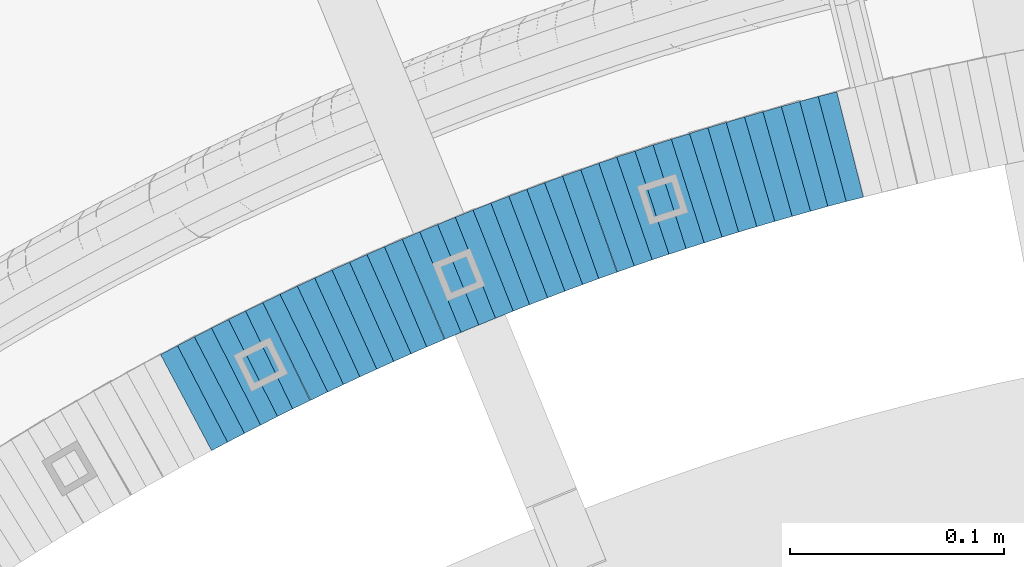
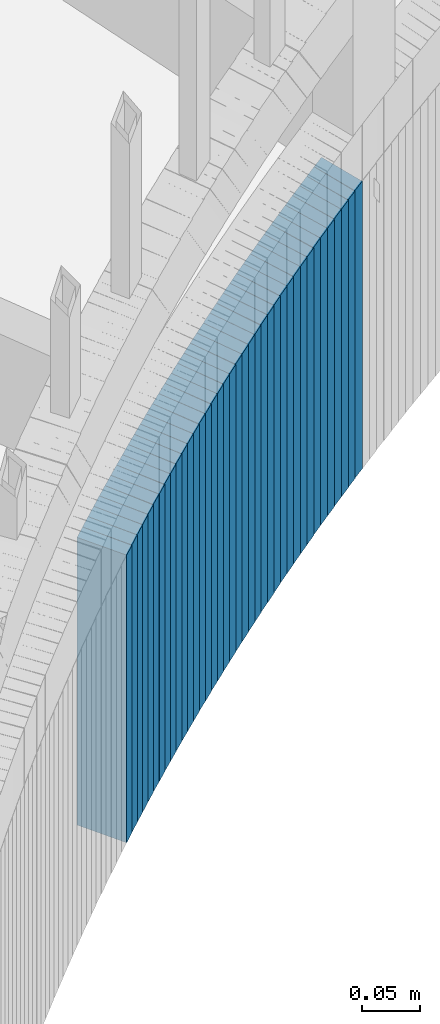
# One storey, part 896 of 975: 38 plates.
"""IFC2X3 building model written with IfcOpenShell, lengths in millimetres."""

import ifcopenshell
import ifcopenshell.guid

model = None  # the IFC model being written
_history = None  # IfcOwnerHistory: only IFC2X3 demands one
_inside = {}  # id of a spatial element -> (the spatial element, [elements in it])
_under = {}  # id of a project, library or spatial element -> (it, [spatial elements below it])
_declared = {}  # id of a project -> (the project, [libraries it declares])
_typed = {}  # id of a type object -> (the type object, [elements of that type])
_made_of = {}  # id of a material, layer set ... -> (it, [elements and type objects made of it])


def new_model(schema):
    """Start an empty IFC model of exactly this schema.

    Asked for "IFC4X3", IfcOpenShell would pick the latest addendum, in which some entities
    have other attributes; the version numbers below select the first issue.
    IFC2X3 requires an IfcOwnerHistory on every rooted entity: one is made here for all.
    """
    global model, _history
    if schema == "IFC4X3":
        model = ifcopenshell.file(schema_version=(4, 3, 0, 0))
    else:
        model = ifcopenshell.file(schema=schema)
    _inside.clear()
    _under.clear()
    _declared.clear()
    _typed.clear()
    _made_of.clear()
    _history = None
    if model.schema == "IFC2X3":
        org = make("IfcOrganization", Name="unknown")
        user = make(
            "IfcPersonAndOrganization",
            ThePerson=make("IfcPerson", FamilyName="unknown"),
            TheOrganization=org,
        )
        app = make(
            "IfcApplication",
            ApplicationDeveloper=org,
            Version="unknown",
            ApplicationFullName="unknown",
            ApplicationIdentifier="unknown",
        )
        _history = make(
            "IfcOwnerHistory",
            OwningUser=user,
            OwningApplication=app,
            ChangeAction="ADDED",
            CreationDate=0,
        )
    return model


def make(cls, **values):
    """One entity of the class cls with the attributes given. An attribute that is None is left unset."""
    return model.create_entity(
        cls, **{name: value for name, value in values.items() if value is not None}
    )


def rooted(cls, **values):
    """An entity with a GlobalId (a new one), such as an element, a storey or a relation."""
    return make(cls, GlobalId=ifcopenshell.guid.new(), OwnerHistory=_history, **values)


def si_unit(unit_type, name, prefix=None):
    """IfcSIUnit, for example si_unit("LENGTHUNIT", "METRE", prefix="MILLI")."""
    return make("IfcSIUnit", UnitType=unit_type, Prefix=prefix, Name=name)


def assignment(units):
    """IfcUnitAssignment: the units of a project."""
    return None if units is None else make("IfcUnitAssignment", Units=units)


def point(xyz):
    """IfcCartesianPoint."""
    return None if xyz is None else make("IfcCartesianPoint", Coordinates=xyz)


def direction(xyz):
    """IfcDirection."""
    return None if xyz is None else make("IfcDirection", DirectionRatios=xyz)


def frame(location, z_axis=None, x_axis=None):
    """IfcAxis2Placement3D, a coordinate frame: its origin and axes. An axis left out is left unset."""
    return make(
        "IfcAxis2Placement3D",
        Location=point(location),
        Axis=direction(z_axis),
        RefDirection=direction(x_axis),
    )


def origin_with_axes():
    """The frame at (0, 0, 0) with the z axis (0, 0, 1) and the x axis (1, 0, 0) written out."""
    return frame((0.0, 0.0, 0.0), z_axis=(0.0, 0.0, 1.0), x_axis=(1.0, 0.0, 0.0))


def place(relative_to, where):
    """IfcLocalPlacement: puts the frame where relative to a parent placement (None: the world)."""
    return make(
        "IfcLocalPlacement", PlacementRelTo=relative_to, RelativePlacement=where
    )


def context(
    kind, dimensions, precision=None, world=None, true_north=None, identifier=None
):
    """IfcGeometricRepresentationContext, for example the 3D "Model" context."""
    return make(
        "IfcGeometricRepresentationContext",
        ContextIdentifier=identifier,
        ContextType=kind,
        CoordinateSpaceDimension=dimensions,
        Precision=precision,
        WorldCoordinateSystem=world,
        TrueNorth=true_north,
    )


def subcontext(parent, identifier, kind, view, scale=None):
    """IfcGeometricRepresentationSubContext, for example "Body" below "Model"."""
    return make(
        "IfcGeometricRepresentationSubContext",
        ContextIdentifier=identifier,
        ContextType=kind,
        ParentContext=parent,
        TargetScale=scale,
        TargetView=view,
    )


def project(units=None, contexts=None):
    """IfcProject with its units and contexts."""
    return rooted(
        "IfcProject",
        Name="project",
        RepresentationContexts=contexts,
        UnitsInContext=assignment(units),
    )


def spatial(cls, under=None, at=None, **own):
    """A site, building, storey or space (cls), placed at a placement, below another one or the project."""
    s = rooted(cls, ObjectPlacement=at, **own)
    if under is not None:
        _under.setdefault(under.id(), (under, []))[1].append(s)
    return s


def faces_of(points, faces, orient=None, outer=None):
    """IfcFace entities. A face is a list of loops; a loop is a list of indices into points, from 0.

    orient and outer hold one flag for each loop. By default every Orientation is true, the
    first loop of a face is its IfcFaceOuterBound and the others are IfcFaceBound.
    """
    made = []
    for i, loops in enumerate(faces):
        bounds = []
        for j, loop in enumerate(loops):
            is_outer = j == 0 if outer is None else outer[i][j]
            bounds.append(
                make(
                    "IfcFaceOuterBound" if is_outer else "IfcFaceBound",
                    Bound=make("IfcPolyLoop", Polygon=[points[k] for k in loop]),
                    Orientation=True if orient is None else orient[i][j],
                )
            )
        made.append(make("IfcFace", Bounds=bounds))
    return made


def faceted_brep(points, faces, orient=None, outer=None, voids=None):
    """IfcFacetedBrep: a solid bounded by flat faces; with voids (closed shells), ...WithVoids."""
    shared = [point(p) for p in points]
    hull = make("IfcClosedShell", CfsFaces=faces_of(shared, faces, orient, outer))
    if voids is None:
        return make("IfcFacetedBrep", Outer=hull)
    return make(
        "IfcFacetedBrepWithVoids",
        Outer=hull,
        Voids=[
            make(cls, CfsFaces=faces_of(shared, fs, o, b)) for cls, fs, o, b in voids
        ],
    )


def shape(context_of_items, identifier, shape_type, items):
    """IfcShapeRepresentation: the items that make up one representation, for example the "Body"."""
    return make(
        "IfcShapeRepresentation",
        ContextOfItems=context_of_items,
        RepresentationIdentifier=identifier,
        RepresentationType=shape_type,
        Items=items,
    )


def material(Name=None, Category=None):
    """IfcMaterial."""
    return make("IfcMaterial", Name=Name, Category=Category)


def made_of(thing, what):
    """Note that an element or type object is made of a material, layer set ...; save() writes the relation."""
    if what is not None:
        _made_of.setdefault(what.id(), (what, []))[1].append(thing)
    return thing


def type_object(cls, material=None, **own):
    """A type object (cls), such as IfcWallType, which elements share."""
    return made_of(rooted(cls, **own), material)


def element(
    cls,
    number,
    at=None,
    inside=None,
    cuts=None,
    type_object=None,
    material=None,
    context=None,
    identifier="Body",
    shape_type=None,
    held_by="IfcProductDefinitionShape",
    body=None,
    shapes=None,
    **own,
):
    """One element of the class cls, such as IfcWall. Its Tag is "e" and its number.

    at: its placement. inside: the storey or other place that contains it. cuts: it is an
    opening in that element (IfcRelVoidsElement). A single representation is given by context,
    identifier, shape_type and body (its items); several are given by shapes. held_by: the class
    of the entity that holds the representations. save() writes the other relations.
    """
    e = rooted(cls, Tag="e%d" % number, ObjectPlacement=at, **own)
    if body is not None:
        shapes = [shape(context, identifier, shape_type, body)]
    if shapes is not None:
        e.Representation = make(held_by, Representations=shapes)
    if inside is not None:
        _inside.setdefault(inside.id(), (inside, []))[1].append(e)
    if cuts is not None:
        rooted(
            "IfcRelVoidsElement", RelatingBuildingElement=cuts, RelatedOpeningElement=e
        )
    if type_object is not None:
        _typed.setdefault(type_object.id(), (type_object, []))[1].append(e)
    return made_of(e, material)


def aggregate(whole, parts):
    """IfcRelAggregates: a whole, such as a stair, and the parts it consists of."""
    return rooted("IfcRelAggregates", RelatingObject=whole, RelatedObjects=parts)


def save(model, path):
    """Write the relations noted so far, then the file.

    IfcRelAggregates (storeys below a building ...), IfcRelContainedInSpatialStructure (elements
    in a storey), IfcRelDefinesByType, IfcRelAssociatesMaterial and IfcRelDeclares: one each for
    every whole, place, type object, material and project.
    """
    for whole, parts in _under.values():
        aggregate(whole, parts)
    for where, things in _inside.values():
        rooted(
            "IfcRelContainedInSpatialStructure",
            RelatedElements=things,
            RelatingStructure=where,
        )
    for kind, things in _typed.values():
        rooted("IfcRelDefinesByType", RelatedObjects=things, RelatingType=kind)
    for what, things in _made_of.values():
        rooted("IfcRelAssociatesMaterial", RelatedObjects=things, RelatingMaterial=what)
    for by, libraries in _declared.values():
        rooted("IfcRelDeclares", RelatingContext=by, RelatedDefinitions=libraries)
    model.write(path)


model = new_model("IFC2X3")

# Units and contexts
model_context = context("Model", 3, precision=1e-05, world=origin_with_axes())
body_context = subcontext(model_context, "Body", "Model", "MODEL_VIEW")
ifc_project = project(units=[si_unit("LENGTHUNIT", "METRE", prefix="MILLI"), si_unit("AREAUNIT", "SQUARE_METRE"), si_unit("VOLUMEUNIT", "CUBIC_METRE"), si_unit("MASSUNIT", "GRAM", prefix="KILO"), si_unit("TIMEUNIT", "SECOND"), si_unit("PLANEANGLEUNIT", "RADIAN"), si_unit("SOLIDANGLEUNIT", "STERADIAN"), si_unit("THERMODYNAMICTEMPERATUREUNIT", "DEGREE_CELSIUS"), si_unit("LUMINOUSINTENSITYUNIT", "LUMEN")], contexts=[model_context])

# Site, building, storey
site_placement = place(None, origin_with_axes())
site = spatial("IfcSite", under=ifc_project, at=site_placement, CompositionType="ELEMENT")
building_placement = place(site_placement, origin_with_axes())
building = spatial("IfcBuilding", under=site, at=building_placement, Name="Undefined", CompositionType="ELEMENT")
storey_placement = place(building_placement, origin_with_axes())
storey = spatial("IfcBuildingStorey", under=building, at=storey_placement, Name="Undefined", CompositionType="ELEMENT", Elevation=0.0)

# Plates
ifc_material = material(Name="STEEL/A36")
plate_type = type_object("IfcPlateType", PredefinedType="NOTDEFINED")
plate_1_placement = place(storey_placement, frame((34378.1025429689, 4754.53267319556, 831.600000000632), z_axis=(0.969483457682417, 0.245156736150867, -1.44854766404024e-10), x_axis=(0.0, 0.0, -1.0)))
element("IfcPlate", 1, at=plate_1_placement, inside=storey, type_object=plate_type, material=ifc_material, Name="WALL", context=body_context, shape_type="Brep", body=[
    faceted_brep([(0.0, -25.3999999999724, -1.81898940354586e-11), (-5.69999980926514, -25.4000000000669, 8.96939277644015), (-5.69999980926514, 25.4000000000524, 8.96939277652928), (0.0, 25.3999999999869, 1.45519152283669e-11), (299.100006103516, -25.4000000000669, 8.96939277644015), (299.100006103516, 25.4000000000524, 8.96939277652928), (304.799987792969, -25.3999999999724, -1.81898940354586e-11), (304.799987792969, 25.3999999999869, 1.45519152283669e-11)], [[[0, 1, 2, 3]], [[1, 4, 5, 2]], [[4, 6, 7, 5]], [[6, 0, 3, 7]], [[5, 7, 3, 2]], [[6, 4, 1, 0]]]),
])
plate_2_placement = place(storey_placement, frame((34369.8379500715, 4752.31992760344, 825.900000000635), z_axis=(0.966048244824465, 0.258361739953056, 0.0), x_axis=(0.0, 0.0, -1.0)))
element("IfcPlate", 2, at=plate_2_placement, inside=storey, type_object=plate_type, material=ifc_material, Name="WALL", context=body_context, shape_type="Brep", body=[
    faceted_brep([(0.0, -25.3999999999724, -1.81898940354586e-11), (-5.69999980926514, -25.3999999999724, 8.90224647524519), (-5.69999980926514, 25.3999999999542, 8.90224647519426), (0.0, 25.3999999999869, 1.45519152283669e-11), (299.100006103516, -25.3999999999724, 8.90224647524519), (299.100006103516, 25.3999999999542, 8.90224647519426), (304.799987792969, -25.3999999999724, -1.81898940354586e-11), (304.799987792969, 25.3999999999869, 1.45519152283669e-11)], [[[0, 1, 2, 3]], [[1, 4, 5, 2]], [[4, 6, 7, 5]], [[6, 0, 3, 7]], [[5, 7, 3, 2]], [[6, 4, 1, 0]]]),
])
plate_3_placement = place(storey_placement, frame((34361.5030556638, 4749.99236696997, 820.200000000635), z_axis=(0.963196301347196, 0.268798967764167, 2.08181518246419e-10), x_axis=(0.0, 0.0, -1.0)))
element("IfcPlate", 3, at=plate_3_placement, inside=storey, type_object=plate_type, material=ifc_material, Name="WALL", context=body_context, shape_type="Brep", body=[
    faceted_brep([(0.0, -25.3999999999724, -1.81898940354586e-11), (-5.69999980926514, -25.3999999999141, 8.92748546604707), (-5.69999980926514, 25.3999999999505, 8.92748546598159), (0.0, 25.3999999999869, 1.45519152283669e-11), (299.100006103516, -25.3999999999141, 8.92748546604707), (299.100006103516, 25.3999999999505, 8.92748546598159), (304.799987792969, -25.3999999999724, -1.81898940354586e-11), (304.799987792969, 25.3999999999869, 1.45519152283669e-11)], [[[0, 1, 2, 3]], [[1, 4, 5, 2]], [[4, 6, 7, 5]], [[6, 0, 3, 7]], [[5, 7, 3, 2]], [[6, 4, 1, 0]]]),
])
plate_4_placement = place(storey_placement, frame((34352.9030556619, 4747.59236697001, 814.400000000635), z_axis=(0.963196301347196, 0.268798967764167, 2.08181518246419e-10), x_axis=(0.0, 0.0, -1.0)))
element("IfcPlate", 4, at=plate_4_placement, inside=storey, type_object=plate_type, material=ifc_material, Name="WALL", context=body_context, shape_type="Brep", body=[
    faceted_brep([(0.0, -25.3999999999724, -1.81898940354586e-11), (-5.80000019073486, -25.399999999976, 8.9274854660398), (-5.80000019073486, 25.4000000000269, 8.92748546601433), (0.0, 25.3999999999869, 1.45519152283669e-11), (299.0, -25.399999999976, 8.9274854660398), (299.0, 25.4000000000269, 8.92748546601433), (304.799987792969, -25.3999999999724, -1.81898940354586e-11), (304.799987792969, 25.3999999999869, 1.45519152283669e-11)], [[[0, 1, 2, 3]], [[1, 4, 5, 2]], [[4, 6, 7, 5]], [[6, 0, 3, 7]], [[5, 7, 3, 2]], [[6, 4, 1, 0]]]),
])
for number, where, z_axis, x_axis, name in (
    (5, (34344.5657778894, 4745.16720991552, 808.700000000638), (0.96024972860554, 0.279142362806125, 4.84069460071625e-11), (0.0, 0.0, -1.0), "WALL"),
    (6, (34335.9657778887, 4742.66720991501, 803.000000000641), (0.96024972860554, 0.279142362806125, 4.84069460071625e-11), (0.0, 0.0, -1.0), "WALL"),
):
    element("IfcPlate", number, at=place(storey_placement, frame(where, z_axis=z_axis, x_axis=x_axis)), inside=storey, type_object=plate_type, material=ifc_material, Name=name, context=body_context, shape_type="Brep", body=[
        faceted_brep([(0.0, -25.3999999999724, -1.81898940354586e-11), (-5.69999980926514, -25.4000000000087, 8.9643735885511), (-5.69999980926514, 25.4000000000669, 8.96437358860567), (0.0, 25.3999999999869, 1.45519152283669e-11), (299.100006103516, -25.4000000000087, 8.9643735885511), (299.100006103516, 25.4000000000669, 8.96437358860567), (304.799987792969, -25.3999999999724, -1.81898940354586e-11), (304.799987792969, 25.3999999999869, 1.45519152283669e-11)], [[[0, 1, 2, 3]], [[1, 4, 5, 2]], [[4, 6, 7, 5]], [[6, 0, 3, 7]], [[5, 7, 3, 2]], [[6, 4, 1, 0]]]),
    ])
plate_5_placement = place(storey_placement, frame((34327.5425865012, 4740.18966928057, 797.200000000646), z_axis=(0.959365501603118, 0.282166323883269, 0.0), x_axis=(0.0, 0.0, -1.0)))
element("IfcPlate", 7, at=plate_5_placement, inside=storey, type_object=plate_type, material=ifc_material, Name="WALL", context=body_context, shape_type="Brep", body=[
    faceted_brep([(0.0, -25.3999999999724, -1.81898940354586e-11), (-5.80000019073486, -25.3999999999905, 8.8617153167761), (-5.80000019073486, 25.4000000000524, 8.86171531681975), (0.0, 25.3999999999869, 1.45519152283669e-11), (299.0, -25.3999999999905, 8.8617153167761), (299.0, 25.4000000000524, 8.86171531681975), (304.799987792969, -25.3999999999724, -1.81898940354586e-11), (304.799987792969, 25.3999999999869, 1.45519152283669e-11)], [[[0, 1, 2, 3]], [[1, 4, 5, 2]], [[4, 6, 7, 5]], [[6, 0, 3, 7]], [[5, 7, 3, 2]], [[6, 4, 1, 0]]]),
])
plate_6_placement = place(storey_placement, frame((34319.3838297664, 4737.62381084795, 791.500000000649), z_axis=(0.954084337540625, 0.299538105855778, 0.0), x_axis=(0.0, 0.0, -1.0)))
element("IfcPlate", 8, at=plate_6_placement, inside=storey, type_object=plate_type, material=ifc_material, Name="WALL", context=body_context, shape_type="Brep", body=[
    faceted_brep([(0.0, -25.3999999999724, -1.81898940354586e-11), (-5.69999980926514, -25.4000000000087, 9.01387786864507), (-5.69999980926514, 25.4000000000124, 9.0138778686669), (0.0, 25.3999999999869, 1.45519152283669e-11), (299.100006103516, -25.4000000000087, 9.01387786864507), (299.100006103516, 25.4000000000124, 9.0138778686669), (304.799987792969, -25.3999999999724, -1.81898940354586e-11), (304.799987792969, 25.3999999999869, 1.45519152283669e-11)], [[[0, 1, 2, 3]], [[1, 4, 5, 2]], [[4, 6, 7, 5]], [[6, 0, 3, 7]], [[5, 7, 3, 2]], [[6, 4, 1, 0]]]),
])
plate_7_placement = place(storey_placement, frame((34310.9651785039, 4734.94950072128, 785.800000000654), z_axis=(0.953072925427516, 0.302740811284235, 5.18711658514804e-10), x_axis=(0.0, 0.0, -1.0)))
element("IfcPlate", 9, at=plate_7_placement, inside=storey, type_object=plate_type, material=ifc_material, Name="WALL", context=body_context, shape_type="Brep", body=[
    faceted_brep([(0.0, -25.3999999999724, -1.81898940354586e-11), (-5.69999980926514, -25.3999999999724, 8.91964149478372), (-5.69999980926514, 25.400000000016, 8.9196414947528), (0.0, 25.3999999999869, 1.45519152283669e-11), (299.100006103516, -25.3999999999724, 8.91964149478372), (299.100006103516, 25.400000000016, 8.9196414947528), (304.799987792969, -25.3999999999724, -1.81898940354586e-11), (304.799987792969, 25.3999999999869, 1.45519152283669e-11)], [[[0, 1, 2, 3]], [[1, 4, 5, 2]], [[4, 6, 7, 5]], [[6, 0, 3, 7]], [[5, 7, 3, 2]], [[6, 4, 1, 0]]]),
])
plate_8_placement = place(storey_placement, frame((34302.4651785038, 4732.24950072073, 780.000000000659), z_axis=(0.953072925427516, 0.302740811284235, 5.18711658514804e-10), x_axis=(0.0, 0.0, -1.0)))
element("IfcPlate", 10, at=plate_8_placement, inside=storey, type_object=plate_type, material=ifc_material, Name="WALL", context=body_context, shape_type="Brep", body=[
    faceted_brep([(0.0, -25.3999999999724, -1.81898940354586e-11), (-5.80000019073486, -25.3999999999724, 8.9196414947728), (-5.80000019073486, 25.4000000000342, 8.91964149478736), (0.0, 25.3999999999869, 1.45519152283669e-11), (299.0, -25.3999999999724, 8.9196414947728), (299.0, 25.4000000000342, 8.91964149478736), (304.799987792969, -25.3999999999724, -1.81898940354586e-11), (304.799987792969, 25.3999999999869, 1.45519152283669e-11)], [[[0, 1, 2, 3]], [[1, 4, 5, 2]], [[4, 6, 7, 5]], [[6, 0, 3, 7]], [[5, 7, 3, 2]], [[6, 4, 1, 0]]]),
])
for number, where, z_axis, x_axis, name in (
    (11, (34294.2225506804, 4729.53276558193, 774.300000000667), (0.949794780959558, 0.312873575205683, -1.32485638459912e-10), (0.0, 0.0, -1.0), "WALL"),
    (12, (34285.7225506817, 4726.732765582, 768.600000000675), (0.949794780959558, 0.312873575205683, -1.32485638459912e-10), (0.0, 0.0, -1.0), "WALL"),
):
    element("IfcPlate", number, at=place(storey_placement, frame(where, z_axis=z_axis, x_axis=x_axis)), inside=storey, type_object=plate_type, material=ifc_material, Name=name, context=body_context, shape_type="Brep", body=[
        faceted_brep([(0.0, -25.3999999999724, -1.81898940354586e-11), (-5.69999980926514, -25.4000000000451, 8.94986057279493), (-5.69999980926514, 25.3999999999942, 8.94986057280948), (0.0, 25.3999999999869, 1.45519152283669e-11), (299.100006103516, -25.4000000000451, 8.94986057279493), (299.100006103516, 25.3999999999942, 8.94986057280948), (304.799987792969, -25.3999999999724, -1.81898940354586e-11), (304.799987792969, 25.3999999999869, 1.45519152283669e-11)], [[[0, 1, 2, 3]], [[1, 4, 5, 2]], [[4, 6, 7, 5]], [[6, 0, 3, 7]], [[5, 7, 3, 2]], [[6, 4, 1, 0]]]),
    ])
plate_9_placement = place(storey_placement, frame((34277.6645333591, 4723.94811838076, 762.900000000682), z_axis=(0.945253332455169, 0.326337459514532, 3.89617525797802e-10), x_axis=(0.0, 0.0, -1.0)))
element("IfcPlate", 13, at=plate_9_placement, inside=storey, type_object=plate_type, material=ifc_material, Name="WALL", context=body_context, shape_type="Brep", body=[
    faceted_brep([(0.0, -25.3999999999724, -1.81898940354586e-11), (-5.69999980926514, -25.4000000000487, 8.88650703422172), (-5.69999980926514, 25.4000000000524, 8.88650703437088), (0.0, 25.3999999999869, 1.45519152283669e-11), (299.100006103516, -25.4000000000487, 8.88650703422172), (299.100006103516, 25.4000000000524, 8.88650703437088), (304.799987792969, -25.3999999999724, -1.81898940354586e-11), (304.799987792969, 25.3999999999869, 1.45519152283669e-11)], [[[0, 1, 2, 3]], [[1, 4, 5, 2]], [[4, 6, 7, 5]], [[6, 0, 3, 7]], [[5, 7, 3, 2]], [[6, 4, 1, 0]]]),
])
plate_10_placement = place(storey_placement, frame((34269.5185063508, 4721.03730846425, 757.100000000686), z_axis=(0.941741911640086, 0.33633639687146, 0.0), x_axis=(0.0, 0.0, -1.0)))
element("IfcPlate", 14, at=plate_10_placement, inside=storey, type_object=plate_type, material=ifc_material, Name="WALL", context=body_context, shape_type="Brep", body=[
    faceted_brep([(0.0, -25.3999999999724, -1.81898940354586e-11), (-5.80000019073486, -25.3999999999724, 8.9196414947728), (-5.80000019073486, 25.4000000000342, 8.91964149478736), (0.0, 25.3999999999869, 1.45519152283669e-11), (299.0, -25.3999999999724, 8.9196414947728), (299.0, 25.4000000000342, 8.91964149478736), (304.799987792969, -25.3999999999724, -1.81898940354586e-11), (304.799987792969, 25.3999999999869, 1.45519152283669e-11)], [[[0, 1, 2, 3]], [[1, 4, 5, 2]], [[4, 6, 7, 5]], [[6, 0, 3, 7]], [[5, 7, 3, 2]], [[6, 4, 1, 0]]]),
])
plate_11_placement = place(storey_placement, frame((34260.9291928645, 4718.00559854777, 751.400000000692), z_axis=(0.942990333545967, 0.332820117839752, 0.0), x_axis=(0.0, 0.0, -1.0)))
element("IfcPlate", 15, at=plate_11_placement, inside=storey, type_object=plate_type, material=ifc_material, Name="WALL", context=body_context, shape_type="Brep", body=[
    faceted_brep([(0.0, -25.3999999999724, -1.81898940354586e-11), (-5.69999980926514, -25.4000000000087, 9.01387786864507), (-5.69999980926514, 25.4000000000124, 9.0138778686669), (0.0, 25.3999999999869, 1.45519152283669e-11), (299.100006103516, -25.4000000000087, 9.01387786864507), (299.100006103516, 25.4000000000124, 9.0138778686669), (304.799987792969, -25.3999999999724, -1.81898940354586e-11), (304.799987792969, 25.3999999999869, 1.45519152283669e-11)], [[[0, 1, 2, 3]], [[1, 4, 5, 2]], [[4, 6, 7, 5]], [[6, 0, 3, 7]], [[5, 7, 3, 2]], [[6, 4, 1, 0]]]),
])
plate_12_placement = place(storey_placement, frame((34252.869622767, 4715.0284847841, 745.700000000699), z_axis=(0.938152292840694, 0.346222869605329, 2.00598151423037e-10), x_axis=(0.0, 0.0, -1.0)))
element("IfcPlate", 16, at=plate_12_placement, inside=storey, type_object=plate_type, material=ifc_material, Name="WALL", context=body_context, shape_type="Brep", body=[
    faceted_brep([(0.0, -25.3999999999724, -1.81898940354586e-11), (-5.69999980926514, -25.4000000000451, 8.94986057279493), (-5.69999980926514, 25.3999999999942, 8.94986057280948), (0.0, 25.3999999999869, 1.45519152283669e-11), (299.100006103516, -25.4000000000451, 8.94986057279493), (299.100006103516, 25.3999999999942, 8.94986057280948), (304.799987792969, -25.3999999999724, -1.81898940354586e-11), (304.799987792969, 25.3999999999869, 1.45519152283669e-11)], [[[0, 1, 2, 3]], [[1, 4, 5, 2]], [[4, 6, 7, 5]], [[6, 0, 3, 7]], [[5, 7, 3, 2]], [[6, 4, 1, 0]]]),
])
plate_13_placement = place(storey_placement, frame((34244.6626724113, 4711.96303125046, 739.900000000713), z_axis=(0.936792195612456, 0.349886241855255, 0.0), x_axis=(0.0, 0.0, -1.0)))
element("IfcPlate", 17, at=plate_13_placement, inside=storey, type_object=plate_type, material=ifc_material, Name="WALL", context=body_context, shape_type="Brep", body=[
    faceted_brep([(0.0, -25.3999999999724, -1.81898940354586e-11), (-5.80000019073486, -25.3999999999905, 8.8617153167761), (-5.80000019073486, 25.4000000000524, 8.86171531681975), (0.0, 25.3999999999869, 1.45519152283669e-11), (299.0, -25.3999999999905, 8.8617153167761), (299.0, 25.4000000000524, 8.86171531681975), (304.799987792969, -25.3999999999724, -1.81898940354586e-11), (304.799987792969, 25.3999999999869, 1.45519152283669e-11)], [[[0, 1, 2, 3]], [[1, 4, 5, 2]], [[4, 6, 7, 5]], [[6, 0, 3, 7]], [[5, 7, 3, 2]], [[6, 4, 1, 0]]]),
])
plate_14_placement = place(storey_placement, frame((34236.4178431976, 4708.8215645553, 734.200000000717), z_axis=(0.934487734802236, 0.355995327924661, 0.0), x_axis=(0.0, 0.0, -1.0)))
element("IfcPlate", 18, at=plate_14_placement, inside=storey, type_object=plate_type, material=ifc_material, Name="WALL", context=body_context, shape_type="Brep", body=[
    faceted_brep([(0.0, -25.3999999999724, -1.81898940354586e-11), (-5.69999980926514, -25.3999999999724, 8.9872131347729), (-5.69999980926514, 25.3999999999833, 8.98721313475835), (0.0, 25.3999999999869, 1.45519152283669e-11), (299.100006103516, -25.3999999999724, 8.9872131347729), (299.100006103516, 25.3999999999833, 8.98721313475835), (304.799987792969, -25.3999999999724, -1.81898940354586e-11), (304.799987792969, 25.3999999999869, 1.45519152283669e-11)], [[[0, 1, 2, 3]], [[1, 4, 5, 2]], [[4, 6, 7, 5]], [[6, 0, 3, 7]], [[5, 7, 3, 2]], [[6, 4, 1, 0]]]),
])
plate_15_placement = place(storey_placement, frame((34228.0178431977, 4705.62156455577, 728.400000000722), z_axis=(0.934487734802236, 0.355995327924661, 0.0), x_axis=(0.0, 0.0, -1.0)))
element("IfcPlate", 19, at=plate_15_placement, inside=storey, type_object=plate_type, material=ifc_material, Name="WALL", context=body_context, shape_type="Brep", body=[
    faceted_brep([(0.0, -25.3999999999724, -1.81898940354586e-11), (-5.80000019073486, -25.3999999999796, 8.98721313478018), (-5.80000019073486, 25.399999999936, 8.98721313473106), (0.0, 25.3999999999869, 1.45519152283669e-11), (299.0, -25.3999999999796, 8.98721313478018), (299.0, 25.399999999936, 8.98721313473106), (304.799987792969, -25.3999999999724, -1.81898940354586e-11), (304.799987792969, 25.3999999999869, 1.45519152283669e-11)], [[[0, 1, 2, 3]], [[1, 4, 5, 2]], [[4, 6, 7, 5]], [[6, 0, 3, 7]], [[5, 7, 3, 2]], [[6, 4, 1, 0]]]),
])
plate_16_placement = place(storey_placement, frame((34220.0598350157, 4702.45468418054, 722.700000000724), z_axis=(0.929246804682174, 0.369459572873635, 0.0), x_axis=(0.0, 0.0, -1.0)))
element("IfcPlate", 20, at=plate_16_placement, inside=storey, type_object=plate_type, material=ifc_material, Name="WALL", context=body_context, shape_type="Brep", body=[
    faceted_brep([(0.0, -25.3999999999724, -1.81898940354586e-11), (-5.69999980926514, -25.3999999999141, 8.92748546604707), (-5.69999980926514, 25.3999999999505, 8.92748546598159), (0.0, 25.3999999999869, 1.45519152283669e-11), (299.100006103516, -25.3999999999141, 8.92748546604707), (299.100006103516, 25.3999999999505, 8.92748546598159), (304.799987792969, -25.3999999999724, -1.81898940354586e-11), (304.799987792969, 25.3999999999869, 1.45519152283669e-11)], [[[0, 1, 2, 3]], [[1, 4, 5, 2]], [[4, 6, 7, 5]], [[6, 0, 3, 7]], [[5, 7, 3, 2]], [[6, 4, 1, 0]]]),
])
plate_17_placement = place(storey_placement, frame((34211.7598350121, 4699.15468418025, 716.900000000727), z_axis=(0.929246804682174, 0.369459572873635, 0.0), x_axis=(0.0, 0.0, -1.0)))
element("IfcPlate", 21, at=plate_17_placement, inside=storey, type_object=plate_type, material=ifc_material, Name="WALL", context=body_context, shape_type="Brep", body=[
    faceted_brep([(0.0, -25.3999999999724, -1.81898940354586e-11), (-5.80000019073486, -25.399999999976, 8.9274854660398), (-5.80000019073486, 25.4000000000269, 8.92748546601433), (0.0, 25.3999999999869, 1.45519152283669e-11), (299.0, -25.399999999976, 8.9274854660398), (299.0, 25.4000000000269, 8.92748546601433), (304.799987792969, -25.3999999999724, -1.81898940354586e-11), (304.799987792969, 25.3999999999869, 1.45519152283669e-11)], [[[0, 1, 2, 3]], [[1, 4, 5, 2]], [[4, 6, 7, 5]], [[6, 0, 3, 7]], [[5, 7, 3, 2]], [[6, 4, 1, 0]]]),
])
for number, where, z_axis, x_axis, name in (
    (22, (34203.703861756, 4695.8531738307, 711.200000000731), (0.925369259401996, 0.379066925164674, 0.0), (0.0, 0.0, -1.0), "WALL"),
    (23, (34195.4038617517, 4692.45317383087, 705.500000000735), (0.925369259401996, 0.379066925164674, 0.0), (0.0, 0.0, -1.0), "WALL"),
):
    element("IfcPlate", number, at=place(storey_placement, frame(where, z_axis=z_axis, x_axis=x_axis)), inside=storey, type_object=plate_type, material=ifc_material, Name=name, context=body_context, shape_type="Brep", body=[
        faceted_brep([(0.0, -25.3999999999724, -1.81898940354586e-11), (-5.69999980926514, -25.4000000000669, 8.96939277644015), (-5.69999980926514, 25.4000000000524, 8.96939277652928), (0.0, 25.3999999999869, 1.45519152283669e-11), (299.100006103516, -25.4000000000669, 8.96939277644015), (299.100006103516, 25.4000000000524, 8.96939277652928), (304.799987792969, -25.3999999999724, -1.81898940354586e-11), (304.799987792969, 25.3999999999869, 1.45519152283669e-11)], [[[0, 1, 2, 3]], [[1, 4, 5, 2]], [[4, 6, 7, 5]], [[6, 0, 3, 7]], [[5, 7, 3, 2]], [[6, 4, 1, 0]]]),
    ])
plate_18_placement = place(storey_placement, frame((34187.5467178824, 4689.09655887436, 699.700000000738), z_axis=(0.919724178958997, 0.392565197945765, 2.16004991671071e-11), x_axis=(0.0, 0.0, -1.0)))
element("IfcPlate", 24, at=plate_18_placement, inside=storey, type_object=plate_type, material=ifc_material, Name="WALL", context=body_context, shape_type="Brep", body=[
    faceted_brep([(0.0, -25.3999999999724, -1.81898940354586e-11), (-5.80000019073486, -25.3999999999724, 8.9196414947728), (-5.80000019073486, 25.4000000000342, 8.91964149478736), (0.0, 25.3999999999869, 1.45519152283669e-11), (299.0, -25.3999999999724, 8.9196414947728), (299.0, 25.4000000000342, 8.91964149478736), (304.799987792969, -25.3999999999724, -1.81898940354586e-11), (304.799987792969, 25.3999999999869, 1.45519152283669e-11)], [[[0, 1, 2, 3]], [[1, 4, 5, 2]], [[4, 6, 7, 5]], [[6, 0, 3, 7]], [[5, 7, 3, 2]], [[6, 4, 1, 0]]]),
])
plate_19_placement = place(storey_placement, frame((34179.1448143221, 4685.55332571665, 694.000000000743), z_axis=(0.921426271776065, 0.388553246905571, 0.0), x_axis=(0.0, 0.0, -1.0)))
element("IfcPlate", 25, at=plate_19_placement, inside=storey, type_object=plate_type, material=ifc_material, Name="WALL", context=body_context, shape_type="Brep", body=[
    faceted_brep([(0.0, -25.3999999999724, -1.81898940354586e-11), (-5.69999980926514, -25.4000000000087, 9.01387786864507), (-5.69999980926514, 25.4000000000124, 9.0138778686669), (0.0, 25.3999999999869, 1.45519152283669e-11), (299.100006103516, -25.4000000000087, 9.01387786864507), (299.100006103516, 25.4000000000124, 9.0138778686669), (304.799987792969, -25.3999999999724, -1.81898940354586e-11), (304.799987792969, 25.3999999999869, 1.45519152283669e-11)], [[[0, 1, 2, 3]], [[1, 4, 5, 2]], [[4, 6, 7, 5]], [[6, 0, 3, 7]], [[5, 7, 3, 2]], [[6, 4, 1, 0]]]),
])
plate_20_placement = place(storey_placement, frame((34171.2861094228, 4682.10019465355, 688.200000000748), z_axis=(0.915644030049762, 0.401990062357556, -1.95650045498041e-10), x_axis=(0.0, 0.0, -1.0)))
element("IfcPlate", 26, at=plate_20_placement, inside=storey, type_object=plate_type, material=ifc_material, Name="WALL", context=body_context, shape_type="Brep", body=[
    faceted_brep([(0.0, -25.3999999999724, -1.81898940354586e-11), (-5.80000019073486, -25.3999999999396, 8.9627008438656), (-5.80000019073486, 25.3999999999178, 8.96270084374191), (0.0, 25.3999999999869, 1.45519152283669e-11), (299.0, -25.3999999999396, 8.9627008438656), (299.0, 25.3999999999178, 8.96270084374191), (304.799987792969, -25.3999999999724, -1.81898940354586e-11), (304.799987792969, 25.3999999999869, 1.45519152283669e-11)], [[[0, 1, 2, 3]], [[1, 4, 5, 2]], [[4, 6, 7, 5]], [[6, 0, 3, 7]], [[5, 7, 3, 2]], [[6, 4, 1, 0]]]),
])
plate_21_placement = place(storey_placement, frame((34163.2914788794, 4678.54673968327, 682.500000000748), z_axis=(0.913811548702731, 0.406138465867881, 0.0), x_axis=(0.0, 0.0, -1.0)))
element("IfcPlate", 27, at=plate_21_placement, inside=storey, type_object=plate_type, material=ifc_material, Name="WALL", context=body_context, shape_type="Brep", body=[
    faceted_brep([(0.0, -25.3999999999724, -1.81898940354586e-11), (-5.69999980926491, -25.3999999999869, 8.86002254486812), (-5.69999980926491, 25.3999999999942, 8.86002254485538), (0.0, 25.3999999999869, 1.45519152283669e-11), (299.100006103516, -25.3999999999869, 8.86002254486812), (299.100006103516, 25.3999999999942, 8.86002254485538), (304.799987792969, -25.3999999999724, -1.81898940354586e-11), (304.799987792969, 25.3999999999869, 1.45519152283669e-11)], [[[0, 1, 2, 3]], [[1, 4, 5, 2]], [[4, 6, 7, 5]], [[6, 0, 3, 7]], [[5, 7, 3, 2]], [[6, 4, 1, 0]]]),
])
plate_22_placement = place(storey_placement, frame((34155.2222990727, 4674.90532458919, 676.700000000754), z_axis=(0.911505056464486, 0.411288866904605, 1.76136381924153e-10), x_axis=(0.0, 0.0, -1.0)))
element("IfcPlate", 28, at=plate_22_placement, inside=storey, type_object=plate_type, material=ifc_material, Name="WALL", context=body_context, shape_type="Brep", body=[
    faceted_brep([(0.0, -25.3999999999724, -1.81898940354586e-11), (-5.80000019073486, -25.3999999999578, 8.99610996247975), (-5.80000019073486, 25.3999999999796, 8.99610996245065), (0.0, 25.3999999999869, 1.45519152283669e-11), (299.0, -25.3999999999578, 8.99610996247975), (299.0, 25.3999999999796, 8.99610996245065), (304.799987792969, -25.3999999999724, -1.81898940354586e-11), (304.799987792969, 25.3999999999869, 1.45519152283669e-11)], [[[0, 1, 2, 3]], [[1, 4, 5, 2]], [[4, 6, 7, 5]], [[6, 0, 3, 7]], [[5, 7, 3, 2]], [[6, 4, 1, 0]]]),
])
plate_23_placement = place(storey_placement, frame((34147.2291185357, 4671.25382082808, 671.000000000757), z_axis=(0.909595755817756, 0.415494357360392, 3.29607246385422e-10), x_axis=(0.0, 0.0, -1.0)))
element("IfcPlate", 29, at=plate_23_placement, inside=storey, type_object=plate_type, material=ifc_material, Name="WALL", context=body_context, shape_type="Brep", body=[
    faceted_brep([(0.0, -25.3999999999724, -1.81898940354586e-11), (-5.69999980926514, -25.400000000096, 8.9140338897214), (-5.69999980926514, 25.4000000000524, 8.91403388979779), (0.0, 25.3999999999869, 1.45519152283669e-11), (299.100006103516, -25.400000000096, 8.9140338897214), (299.100006103516, 25.4000000000524, 8.91403388979779), (304.799987792969, -25.3999999999724, -1.81898940354586e-11), (304.799987792969, 25.3999999999869, 1.45519152283669e-11)], [[[0, 1, 2, 3]], [[1, 4, 5, 2]], [[4, 6, 7, 5]], [[6, 0, 3, 7]], [[5, 7, 3, 2]], [[6, 4, 1, 0]]]),
])
plate_24_placement = place(storey_placement, frame((34139.363455209, 4667.56230662443, 665.300000000762), z_axis=(0.905324661295672, 0.424720211021181, 6.89760781824589e-11), x_axis=(0.0, 0.0, -1.0)))
element("IfcPlate", 30, at=plate_24_placement, inside=storey, type_object=plate_type, material=ifc_material, Name="WALL", context=body_context, shape_type="Brep", body=[
    faceted_brep([(0.0, -25.3999999999724, -1.81898940354586e-11), (-5.69999980926514, -25.4000000000451, 8.94986057279493), (-5.69999980926514, 25.3999999999942, 8.94986057280948), (0.0, 25.3999999999869, 1.45519152283669e-11), (299.100006103516, -25.4000000000451, 8.94986057279493), (299.100006103516, 25.3999999999942, 8.94986057280948), (304.799987792969, -25.3999999999724, -1.81898940354586e-11), (304.799987792969, 25.3999999999869, 1.45519152283669e-11)], [[[0, 1, 2, 3]], [[1, 4, 5, 2]], [[4, 6, 7, 5]], [[6, 0, 3, 7]], [[5, 7, 3, 2]], [[6, 4, 1, 0]]]),
])
plate_25_placement = place(storey_placement, frame((34131.2634552085, 4663.76230662466, 659.500000000767), z_axis=(0.905324661295672, 0.424720211021181, 6.89760781824589e-11), x_axis=(0.0, 0.0, -1.0)))
element("IfcPlate", 31, at=plate_25_placement, inside=storey, type_object=plate_type, material=ifc_material, Name="WALL", context=body_context, shape_type="Brep", body=[
    faceted_brep([(0.0, -25.3999999999724, -1.81898940354586e-11), (-5.80000019073486, -25.4000000000742, 8.94706630702785), (-5.80000019073486, 25.4000000000306, 8.9470663070897), (0.0, 25.3999999999869, 1.45519152283669e-11), (299.0, -25.4000000000742, 8.94706630702785), (299.0, 25.4000000000306, 8.9470663070897), (304.799987792969, -25.3999999999724, -1.81898940354586e-11), (304.799987792969, 25.3999999999869, 1.45519152283669e-11)], [[[0, 1, 2, 3]], [[1, 4, 5, 2]], [[4, 6, 7, 5]], [[6, 0, 3, 7]], [[5, 7, 3, 2]], [[6, 4, 1, 0]]]),
])
plate_26_placement = place(storey_placement, frame((34123.6058989285, 4660.02609234665, 653.800000000769), z_axis=(0.898876404534364, 0.438202247108996, 8.72196324053222e-11), x_axis=(0.0, 0.0, -1.0)))
element("IfcPlate", 32, at=plate_26_placement, inside=storey, type_object=plate_type, material=ifc_material, Name="WALL", context=body_context, shape_type="Brep", body=[
    faceted_brep([(0.0, -25.3999999999724, -1.81898940354586e-11), (-5.69999980926514, -25.3999999999724, 8.90224647524519), (-5.69999980926514, 25.3999999999542, 8.90224647519426), (0.0, 25.3999999999869, 1.45519152283669e-11), (299.100006103516, -25.3999999999724, 8.90224647524519), (299.100006103516, 25.3999999999542, 8.90224647519426), (304.799987792969, -25.3999999999724, -1.81898940354586e-11), (304.799987792969, 25.3999999999869, 1.45519152283669e-11)], [[[0, 1, 2, 3]], [[1, 4, 5, 2]], [[4, 6, 7, 5]], [[6, 0, 3, 7]], [[5, 7, 3, 2]], [[6, 4, 1, 0]]]),
])
plate_27_placement = place(storey_placement, frame((34115.3944785665, 4656.07211060904, 648.100000000775), z_axis=(0.901001669715669, 0.433815618863102, 0.0), x_axis=(0.0, 0.0, -1.0)))
element("IfcPlate", 33, at=plate_27_placement, inside=storey, type_object=plate_type, material=ifc_material, Name="WALL", context=body_context, shape_type="Brep", body=[
    faceted_brep([(0.0, -25.3999999999724, -1.81898940354586e-11), (-5.69999980926514, -25.3999999999724, 8.9872131347729), (-5.69999980926514, 25.3999999999833, 8.98721313475835), (0.0, 25.3999999999869, 1.45519152283669e-11), (299.100006103516, -25.3999999999724, 8.9872131347729), (299.100006103516, 25.3999999999833, 8.98721313475835), (304.799987792969, -25.3999999999724, -1.81898940354586e-11), (304.799987792969, 25.3999999999869, 1.45519152283669e-11)], [[[0, 1, 2, 3]], [[1, 4, 5, 2]], [[4, 6, 7, 5]], [[6, 0, 3, 7]], [[5, 7, 3, 2]], [[6, 4, 1, 0]]]),
])
plate_28_placement = place(storey_placement, frame((34107.7347871836, 4652.23910237369, 642.400000000779), z_axis=(0.894427191057652, 0.447213595384486, -2.02726596398862e-10), x_axis=(0.0, 0.0, -1.0)))
element("IfcPlate", 34, at=plate_28_placement, inside=storey, type_object=plate_type, material=ifc_material, Name="WALL", context=body_context, shape_type="Brep", body=[
    faceted_brep([(0.0, -25.3999999999724, -1.81898940354586e-11), (-5.69999980926514, -25.4000000000415, 8.93756103511259), (-5.69999980926514, 25.4000000000815, 8.93756103522537), (0.0, 25.3999999999869, 1.45519152283669e-11), (299.100006103516, -25.4000000000415, 8.93756103511259), (299.100006103516, 25.4000000000815, 8.93756103522537), (304.799987792969, -25.3999999999724, -1.81898940354586e-11), (304.799987792969, 25.3999999999869, 1.45519152283669e-11)], [[[0, 1, 2, 3]], [[1, 4, 5, 2]], [[4, 6, 7, 5]], [[6, 0, 3, 7]], [[5, 7, 3, 2]], [[6, 4, 1, 0]]]),
])
plate_29_placement = place(storey_placement, frame((34099.9493804852, 4648.29676119958, 636.600000000782), z_axis=(0.892157158272551, 0.451725143137999, 0.0), x_axis=(0.0, 0.0, -1.0)))
element("IfcPlate", 35, at=plate_29_placement, inside=storey, type_object=plate_type, material=ifc_material, Name="WALL", context=body_context, shape_type="Brep", body=[
    faceted_brep([(0.0, -25.3999999999724, -1.81898940354586e-11), (-5.80000019073486, -25.4000000000196, 8.85494232183191), (-5.80000019073486, 25.3999999999905, 8.85494232178462), (0.0, 25.3999999999869, 1.45519152283669e-11), (299.0, -25.4000000000196, 8.85494232183191), (299.0, 25.3999999999905, 8.85494232178462), (304.799987792969, -25.3999999999724, -1.81898940354586e-11), (304.799987792969, 25.3999999999869, 1.45519152283669e-11)], [[[0, 1, 2, 3]], [[1, 4, 5, 2]], [[4, 6, 7, 5]], [[6, 0, 3, 7]], [[5, 7, 3, 2]], [[6, 4, 1, 0]]]),
])
plate_30_placement = place(storey_placement, frame((34092.0602679327, 4644.25324845384, 630.900000000787), z_axis=(0.889933250590133, 0.456090790845507, -3.13543750962708e-11), x_axis=(0.0, 0.0, -1.0)))
element("IfcPlate", 36, at=plate_30_placement, inside=storey, type_object=plate_type, material=ifc_material, Name="WALL", context=body_context, shape_type="Brep", body=[
    faceted_brep([(0.0, -25.3999999999724, -1.81898940354586e-11), (-5.69999980926514, -25.3999999999724, 8.9872131347729), (-5.69999980926514, 25.3999999999833, 8.98721313475835), (0.0, 25.3999999999869, 1.45519152283669e-11), (299.100006103516, -25.3999999999724, 8.9872131347729), (299.100006103516, 25.3999999999833, 8.98721313475835), (304.799987792969, -25.3999999999724, -1.81898940354586e-11), (304.799987792969, 25.3999999999869, 1.45519152283669e-11)], [[[0, 1, 2, 3]], [[1, 4, 5, 2]], [[4, 6, 7, 5]], [[6, 0, 3, 7]], [[5, 7, 3, 2]], [[6, 4, 1, 0]]]),
])
plate_31_placement = place(storey_placement, frame((34084.2759469, 4640.21290865415, 625.200000000789), z_axis=(0.887584423987997, 0.460645080614019, 2.15857426155708e-10), x_axis=(0.0, 0.0, -1.0)))
element("IfcPlate", 37, at=plate_31_placement, inside=storey, type_object=plate_type, material=ifc_material, Name="WALL", context=body_context, shape_type="Brep", body=[
    faceted_brep([(0.0, -25.3999999999724, -1.81898940354586e-11), (-5.69999980926514, -25.3999999999724, 8.90224647524519), (-5.69999980926514, 25.3999999999542, 8.90224647519426), (0.0, 25.3999999999869, 1.45519152283669e-11), (299.100006103516, -25.3999999999724, 8.90224647524519), (299.100006103516, 25.3999999999542, 8.90224647519426), (304.799987792969, -25.3999999999724, -1.81898940354586e-11), (304.799987792969, 25.3999999999869, 1.45519152283669e-11)], [[[0, 1, 2, 3]], [[1, 4, 5, 2]], [[4, 6, 7, 5]], [[6, 0, 3, 7]], [[5, 7, 3, 2]], [[6, 4, 1, 0]]]),
])
plate_32_placement = place(storey_placement, frame((34076.5990229362, 4636.13009048659, 619.400000000795), z_axis=(0.882970965834001, 0.469427601973053, -3.50903519574786e-11), x_axis=(0.0, 0.0, -1.0)))
element("IfcPlate", 38, at=plate_32_placement, inside=storey, type_object=plate_type, material=ifc_material, Name="WALL", context=body_context, shape_type="Brep", body=[
    faceted_brep([(0.0, -25.3999999999724, -1.81898940354586e-11), (-5.80000019073486, -25.4000000000742, 8.94706630702785), (-5.80000019073486, 25.4000000000306, 8.9470663070897), (0.0, 25.3999999999869, 1.45519152283669e-11), (299.0, -25.4000000000742, 8.94706630702785), (299.0, 25.4000000000306, 8.9470663070897), (304.799987792969, -25.3999999999724, -1.81898940354586e-11), (304.799987792969, 25.3999999999869, 1.45519152283669e-11)], [[[0, 1, 2, 3]], [[1, 4, 5, 2]], [[4, 6, 7, 5]], [[6, 0, 3, 7]], [[5, 7, 3, 2]], [[6, 4, 1, 0]]]),
])

save(model, "model.ifc")
